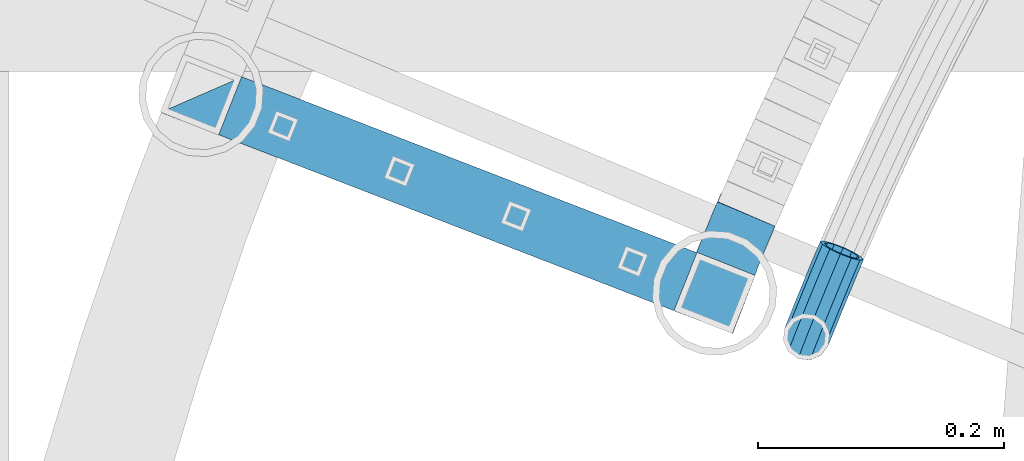
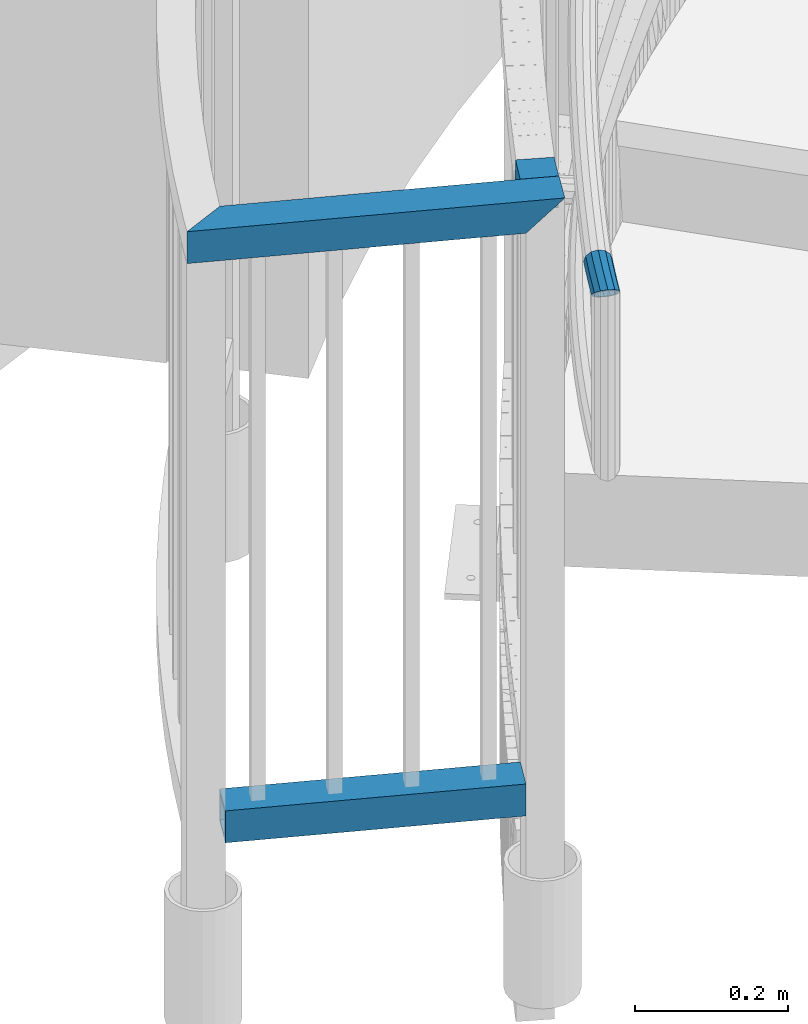
# One storey, part 480 of 975: 4 beams.
"""IFC2X3 building model written with IfcOpenShell, lengths in millimetres."""

from ifc_helpers import new_model, si_unit, frame, origin_with_axes, place, context, subcontext, project, spatial, faceted_brep, material, type_object, element, save


model = new_model("IFC2X3")

# Units and contexts
model_context = context("Model", 3, precision=1e-05, world=origin_with_axes())
body_context = subcontext(model_context, "Body", "Model", "MODEL_VIEW")
ifc_project = project(units=[si_unit("LENGTHUNIT", "METRE", prefix="MILLI"), si_unit("AREAUNIT", "SQUARE_METRE"), si_unit("VOLUMEUNIT", "CUBIC_METRE"), si_unit("MASSUNIT", "GRAM", prefix="KILO"), si_unit("TIMEUNIT", "SECOND"), si_unit("PLANEANGLEUNIT", "RADIAN"), si_unit("SOLIDANGLEUNIT", "STERADIAN"), si_unit("THERMODYNAMICTEMPERATUREUNIT", "DEGREE_CELSIUS"), si_unit("LUMINOUSINTENSITYUNIT", "LUMEN")], contexts=[model_context])

# Site, building, storey
site_placement = place(None, origin_with_axes())
site = spatial("IfcSite", under=ifc_project, at=site_placement, CompositionType="ELEMENT")
building_placement = place(site_placement, origin_with_axes())
building = spatial("IfcBuilding", under=site, at=building_placement, Name="Undefined", CompositionType="ELEMENT")
storey_placement = place(building_placement, origin_with_axes())
storey = spatial("IfcBuildingStorey", under=building, at=storey_placement, Name="Undefined", CompositionType="ELEMENT", Elevation=0.0)

# Beams
ifc_material = material()
beam_type_1 = type_object("IfcBeamType", PredefinedType="NOTDEFINED")
beam_1_placement = place(storey_placement, frame((32141.6837100169, 4427.4633907106, 895.35), z_axis=(-0.921304073140395, 0.388842905059251, 0.0), x_axis=(0.388842905059251, 0.921304073140395, 0.0)))
element("IfcBeam", 1, at=beam_1_placement, inside=storey, type_object=beam_type_1, material=ifc_material, Name="HANDRAIL", context=body_context, shape_type="Brep", body=[
    faceted_brep([(25.8282079449309, 16.4977839420935, 10.0075676482193), (25.7308276101321, 9.52499999999998, 16.9796715612138), (38.7896490832063, 9.52499999999998, 17.1316638384778), (38.8545704789321, 16.4977839420935, 10.1591821342627), (51.8490366294463, 9.52499999999998, 17.2228605224882), (51.8814976790673, 16.4977839420935, 10.2501521402701), (64.9087072153307, 9.52499999999998, 17.25325963676), (64.9087072153307, 16.4977839420935, 10.2804756946607), (51.8371550606498, 0.0, 19.7750489235623), (64.9087072153307, 0.0, 19.8054756946658), (38.765886203124, 0.0, 19.683769269639), (25.6951839337671, 0.0, 19.5316387111925), (12.6728552314671, 9.52499999999998, 16.7668869847985), (12.6253315313188, 0.0, 19.3186605453229), (-0.443387743907806, 0.0, 19.0448393878469), (-0.383985049949843, -9.52499999999998, 16.4933147208685), (12.6728552314671, -9.52499999999998, 16.7668869847985), (25.7308276101321, -9.52499999999998, 16.9796715612138), (38.7896490832063, -9.52499999999998, 17.1316638384778), (51.8490366294463, -9.52499999999998, 17.2228605224882), (64.9087072153307, -9.52499999999998, 17.25325963676), (51.8814976790673, -16.4977839420935, 10.2501521402701), (64.9087072153307, -16.4977839420935, 10.2804756946607), (38.8545704789321, -16.4977839420935, 10.1591821342627), (25.8282079449309, -16.4977839420935, 10.0075676482193), (12.802692394831, -16.4977839420935, 9.79531196804601), (-0.221693871953903, -16.4977839420935, 9.5224196939198), (-12.9786465048091, -19.05, -0.332387692884367), (-12.7126244291394, -16.4977839420935, -9.8536721259552), (0.221693871957541, -16.4977839420935, -9.52241969393071), (-2.63386027654633e-07, -19.0500000000029, 0.0), (-13.2446685804789, -16.4977839420935, 9.18889674017919), (12.9800532583431, -19.05, 0.271963390772726), (25.9612319560911, -19.05, 0.48349658524603), (38.9432547547403, -19.05, 0.634594998889952), (51.9258402974883, -19.05, 0.725255356981506), (64.9087072153343, -19.05, 0.755475694651977), (51.9701829159058, -16.4977839420935, -8.79964142630706), (64.9087072153343, -16.4977839420935, -8.76952430534948), (39.0319390305485, -16.4977839420935, -8.8899921364864), (26.0942559672549, -16.4977839420935, -9.04057447773084), (13.1574141218553, -16.4977839420935, -9.25138518649692), (0.38398504995348, -9.52499999999998, -16.4933147208758), (0.443387743911444, 0.0, -19.0448393878578), (13.3347749853674, 0.0, -18.7747337637702), (13.2872512852191, -9.52499999999998, -16.2229602032457), (26.19163630205, -9.52499999999998, -16.0126783907217), (39.0968604262744, -9.52499999999998, -15.8624738407016), (52.0026439655303, -9.52499999999998, -15.7723498085252), (64.9087072153343, -9.52499999999998, -15.7423082474488), (52.0145255343268, 0.0, -18.3245382095993), (64.9087072153343, 0.0, -18.2945243053582), (39.1206233063604, 0.0, -18.4145792718591), (26.227279978415, 0.0, -18.5646455407004), (13.2872512852191, 9.52499999999998, -16.2229602032457), (26.19163630205, 9.52499999999998, -16.0126783907217), (39.0968604262744, 9.52499999999998, -15.8624738407016), (52.0026439655303, 9.52499999999998, -15.7723498085252), (64.9087072153343, 9.52499999999998, -15.7423082474488), (51.9701829159058, 16.4977839420935, -8.79964142630706), (64.9087072153343, 16.4977839420935, -8.76952430534948), (39.0319390305485, 16.4977839420935, -8.8899921364864), (26.0942559672549, 16.4977839420935, -9.04057447773084), (25.9612319560911, 19.05, 0.48349658524603), (38.9432547547403, 19.05, 0.634594998889952), (51.9258402974883, 19.05, 0.725255356981506), (64.9087072153343, 19.05, 0.755475694651977), (77.3648074792327, 19.05, 0.726481516496278), (76.9388767530545, 16.4977839420935, -8.79752704067141), (75.8195085449479, 9.52499999999998, -15.7677054191918), (74.3066366623061, 0.0, -18.3163999514218), (72.805633904336, -9.52499999999998, -15.76068999571), (71.7186927478688, -16.4977839420935, -8.78537597076865), (71.3370581980053, -19.05, 0.740512363459857), (71.7629889241798, -16.4977839420935, 10.2645209206312), (72.8823571322901, -9.52499999999998, 17.2346992991406), (74.3952290149318, 0.0, 19.7833938313779), (75.8962317729056, 9.52499999999998, 17.2276838756625), (76.9831729293692, 16.4977839420935, 10.2523698507248), (17.6466109170033, 19.05, 0.348006704844011), (14.8706654742964, 16.4977839420935, 9.8290103679974), (12.7643684389404, 14.4396315817753, 11.8531074906132), (7.73531374615777, 9.52499999999998, 16.6634335938325), (-0.434629931831296, 1.40428244019654, 18.6686649746625), (-1.84727105193087, 0.0, 19.0088854435235), (-11.3088929325968, -9.52499999999998, 16.2135239950221), (-13.3801476945264, -11.6469137351224, 14.0378746917268), (-18.1146737379131, -16.4977839420935, 9.04148458933923), (-20.4416500639127, -19.05, -0.558288358450227), (-17.6665438794953, -16.4977839420935, -10.0036243123795), (-12.5735908365059, -11.5196445659184, -14.8298696008133), (-10.5327251734561, -9.52499999999998, -16.7728955017956), (-0.951029722582462, 0.0, -19.0805509086531), (0.434687823712011, 1.39499969402129, -18.6711516052092), (8.51148240332623, 9.52499999999998, -16.3230240683843), (13.1978639579211, 14.3254631666617, -11.4233293299185), (15.3187968882012, 16.4977839420935, -9.21616464052568), (12.836982161778, 13.3082123799554, 7.95413124310653), (11.7249554015616, 13.3082123799554, 7.93083160308743), (12.9128894969181, 14.4005160360366, 3.87830528124687), (12.7322468499951, 7.68349999999998, 13.5778684232901), (5.96928771430976, 7.68349999999998, 13.4361681342634), (-12.7640553637684, -13.3082123799554, -8.0128904688936), (-12.9786465048091, -15.367, -0.332387692884367), (-2.1246523829177e-07, -15.367000000002, 0.0), (0.178833056714211, -13.3082123799554, -7.68141855310751), (-13.1932376458535, -13.3082123799554, 7.34811508312487), (-0.178833056710573, -13.3082123799554, 7.68141855309659), (12.836982161778, -13.3082123799554, 7.95413124310653), (12.9800532583431, -15.367, 0.271963390772726), (13.1231243549082, -13.3082123799554, -7.41020446155744), (0.309747940296802, -7.68349999999998, -13.3046072081779), (13.2278596666874, -7.68349999999998, -13.0339416417337), (0.357666113421146, 0.0, -15.3628371062041), (13.2661954514733, 0.0, -15.0923723138876), (13.1231243549082, 13.3082123799554, -7.41020446155744), (13.0497213343151, 14.3644790452753, -3.46884706227866), (12.0864398226367, 13.3082123799554, -7.43192550036838), (13.2278596666874, 7.68349999999998, -13.0339416417337), (6.59539709775709, 7.68349999999998, -13.1729077132622), (0.348960484243435, 1.3959151074331, -14.9889041057213), (-1.03766638442175, 0.0, -15.3985720612764), (-8.76690071479243, -7.68349999999998, -13.5370633664097), (-12.714724737034, -11.5419145324909, -9.77849930871162), (-14.5217597188421, -13.3082123799554, -8.06609513113654), (-16.760345374274, -15.367, -0.446857461636682), (-14.8832511379696, -13.3082123799554, 7.29695938291479), (-13.2402522840785, -11.6248391938348, 9.03083160932511), (-0.309747940293164, -7.68349999999998, 13.304607208167), (-9.39300937383086, -7.68349999999998, 13.0719816943529), (-0.357666113417508, 0.0, 15.3628371061932), (-1.76063439009522, 0.0, 15.3269065961467), (-0.348914009562577, 1.40336714869977, 14.9869078781921), (12.6939110652092, 0.0, 15.6362990954367), (12.7322468499951, -7.68349999999998, 13.5778684232901), (25.7753724503527, -7.68349999999998, 13.7904110658601), (25.8539259204226, -13.3082123799554, 8.16624724271242), (25.9612319560911, -15.367, 0.48349658524603), (26.0685379917632, -13.3082123799554, -7.19925407222036), (26.1470914618294, -7.68349999999998, -12.8234178953644), (26.1758440274316, 0.0, -14.8820047296831), (26.1470914618294, 7.68349999999998, -12.8234178953644), (26.0685379917632, 13.3082123799554, -7.19925407222036), (25.9612319560911, 15.367, 0.48349658524603), (13.9640962499288, 15.367, 0.287998741827323), (25.8539259204226, 13.3082123799554, 8.16624724271242), (25.7753724503527, 7.68349999999998, 13.7904110658601), (25.7466198847505, 0.0, 15.8489979001788), (38.8001774564364, 0.0, 16.0009289106274), (38.8193461797055, -7.68349999999998, 13.9422305294902), (38.8717161055902, -13.3082123799554, 8.31776195475686), (38.9432547547403, -15.367, 0.634594998889952), (39.0147934038941, -13.3082123799554, -7.0485719569806), (39.0671633297789, -7.68349999999998, -12.6730405317103), (39.086332053048, 0.0, -14.7317389128511), (39.0671633297789, 7.68349999999998, -12.6730405317103), (39.0147934038941, 13.3082123799554, -7.0485719569806), (38.9432547547403, 15.367, 0.634594998889952), (38.8717161055902, 13.3082123799554, 8.31776195475686), (38.8193461797055, 7.68349999999998, 13.9422305294902), (51.8638853386001, 7.68349999999998, 14.0333235238213), (51.8543008731067, 0.0, 16.0920888340188), (51.8638853386001, -7.68349999999998, 14.0333235238213), (51.8900705852975, -13.3082123799554, 8.40867209549833), (51.9258402974883, -15.367, 0.725255356981506), (51.9616100096791, -13.3082123799554, -6.95816138153896), (51.9877952563766, -7.68349999999998, -12.5828128098619), (51.9973797218699, 0.0, -14.6415781200594), (51.9877952563766, 7.68349999999998, -12.5828128098619), (51.9616100096791, 13.3082123799554, -6.95816138153896), (51.9258402974883, 15.367, 0.725255356981506), (51.8900705852975, 13.3082123799554, 8.40867209549833), (64.9087072153307, 13.3082123799554, 8.43897569466208), (64.9087072153307, 7.68349999999998, 14.0636880746206), (64.9087072153307, 0.0, 16.1224756946649), (64.9087072153307, -7.68349999999998, 14.0636880746206), (64.9087072153307, -13.3082123799554, 8.43897569466208), (64.9087072153343, -15.367, 0.755475694651977), (64.9087072153307, -13.3082123799554, -6.92802430535085), (64.9087072153343, -7.68349999999998, -12.5527366853094), (64.9087072153343, 0.0, -14.6115243053537), (64.9087072153343, 7.68349999999998, -12.5527366853094), (64.9087072153307, 13.3082123799554, -6.92802430535085), (64.9087072153343, 15.367, 0.755475694651977), (76.7821250487141, 15.367, 0.727837831702345), (76.47427317849, 13.3082123799554, 8.41205442131104), (75.5974739789417, 7.68349999999998, 14.0388077347634), (74.3866650875098, 0.0, 16.1004137657073), (73.1662817688448, -7.68349999999998, 14.0444668430391), (72.2633247476369, -13.3082123799554, 8.42185628437073), (71.9197406285239, -15.367, 0.739156048250152), (72.227592498748, -13.3082123799554, -6.94506054135854), (73.1043916982962, -7.68349999999998, -12.5718138548109), (74.3152005897282, 0.0, -14.6334198857512), (75.5355839083895, 7.68349999999998, -12.5774729630866), (76.4385409295974, 13.3082123799554, -6.9548624044146)], [[[0, 1, 2, 3]], [[3, 2, 4, 5]], [[5, 4, 6, 7]], [[4, 8, 9, 6]], [[2, 10, 8, 4]], [[1, 11, 10, 2]], [[12, 13, 11, 1]], [[14, 15, 16, 13]], [[13, 16, 17, 11]], [[11, 17, 18, 10]], [[10, 18, 19, 8]], [[8, 19, 20, 9]], [[19, 21, 22, 20]], [[18, 23, 21, 19]], [[17, 24, 23, 18]], [[16, 25, 24, 17]], [[15, 26, 25, 16]], [[27, 28, 29, 30]], [[31, 27, 30, 26]], [[26, 30, 32, 25]], [[25, 32, 33, 24]], [[24, 33, 34, 23]], [[23, 34, 35, 21]], [[21, 35, 36, 22]], [[35, 37, 38, 36]], [[34, 39, 37, 35]], [[33, 40, 39, 34]], [[32, 41, 40, 33]], [[30, 29, 41, 32]], [[42, 43, 44, 45]], [[29, 42, 45, 41]], [[41, 45, 46, 40]], [[40, 46, 47, 39]], [[39, 47, 48, 37]], [[37, 48, 49, 38]], [[48, 50, 51, 49]], [[47, 52, 50, 48]], [[46, 53, 52, 47]], [[45, 44, 53, 46]], [[44, 54, 55, 53]], [[53, 55, 56, 52]], [[52, 56, 57, 50]], [[50, 57, 58, 51]], [[57, 59, 60, 58]], [[56, 61, 59, 57]], [[55, 62, 61, 56]], [[62, 63, 64, 61]], [[61, 64, 65, 59]], [[59, 65, 66, 60]], [[60, 66, 67, 68]], [[58, 60, 68, 69]], [[51, 58, 69, 70]], [[49, 51, 70, 71]], [[38, 49, 71, 72]], [[36, 38, 72, 73]], [[22, 36, 73, 74]], [[20, 22, 74, 75]], [[9, 20, 75, 76]], [[6, 9, 76, 77]], [[7, 6, 77, 78]], [[66, 7, 78, 67]], [[65, 5, 7, 66]], [[64, 3, 5, 65]], [[63, 0, 3, 64]], [[0, 63, 79, 80]], [[12, 1, 0, 80, 81]], [[12, 81, 82]], [[14, 13, 12, 82, 83]], [[14, 83, 84]], [[15, 14, 84, 85]], [[31, 26, 15, 85, 86]], [[31, 86, 87]], [[27, 31, 87, 88]], [[28, 27, 88, 89]], [[28, 89, 90]], [[42, 29, 28, 90, 91]], [[43, 42, 91, 92]], [[43, 92, 93]], [[54, 44, 43, 93, 94]], [[54, 94, 95]], [[62, 55, 54, 95, 96]], [[63, 62, 96, 79]], [[97, 98, 99]], [[97, 100, 101, 98]], [[102, 103, 104, 105]], [[103, 106, 107, 104]], [[104, 107, 108, 109]], [[105, 104, 109, 110]], [[111, 105, 110, 112]], [[113, 111, 112, 114]], [[115, 116, 117]], [[118, 115, 117, 119]], [[113, 114, 118, 119, 120]], [[113, 120, 121]], [[111, 113, 121, 122]], [[102, 105, 111, 122, 123]], [[102, 123, 124]], [[103, 102, 124, 125]], [[106, 103, 125, 126]], [[106, 126, 127]], [[128, 107, 106, 127, 129]], [[130, 128, 129, 131]], [[130, 131, 132]], [[100, 133, 130, 132, 101]], [[128, 130, 133, 134]], [[107, 128, 134, 108]], [[108, 134, 135, 136]], [[109, 108, 136, 137]], [[110, 109, 137, 138]], [[112, 110, 138, 139]], [[114, 112, 139, 140]], [[118, 114, 140, 141]], [[115, 118, 141, 142]], [[115, 142, 143, 144, 116]], [[95, 94, 93, 92, 91, 90, 89, 88, 87, 86, 85, 84, 83, 82, 81, 80, 79, 96], [98, 101, 132, 131, 129, 127, 126, 125, 124, 123, 122, 121, 120, 119, 117, 116, 144, 99]], [[143, 145, 97, 99, 144]], [[100, 97, 145, 146]], [[133, 100, 146, 147]], [[134, 133, 147, 135]], [[135, 147, 148, 149]], [[136, 135, 149, 150]], [[137, 136, 150, 151]], [[138, 137, 151, 152]], [[139, 138, 152, 153]], [[140, 139, 153, 154]], [[141, 140, 154, 155]], [[142, 141, 155, 156]], [[143, 142, 156, 157]], [[145, 143, 157, 158]], [[146, 145, 158, 159]], [[147, 146, 159, 148]], [[148, 159, 160, 161]], [[149, 148, 161, 162]], [[150, 149, 162, 163]], [[151, 150, 163, 164]], [[152, 151, 164, 165]], [[153, 152, 165, 166]], [[154, 153, 166, 167]], [[155, 154, 167, 168]], [[156, 155, 168, 169]], [[157, 156, 169, 170]], [[158, 157, 170, 171]], [[159, 158, 171, 160]], [[160, 171, 172, 173]], [[161, 160, 173, 174]], [[162, 161, 174, 175]], [[163, 162, 175, 176]], [[164, 163, 176, 177]], [[165, 164, 177, 178]], [[166, 165, 178, 179]], [[167, 166, 179, 180]], [[168, 167, 180, 181]], [[169, 168, 181, 182]], [[170, 169, 182, 183]], [[171, 170, 183, 172]], [[172, 183, 184, 185]], [[173, 172, 185, 186]], [[174, 173, 186, 187]], [[175, 174, 187, 188]], [[176, 175, 188, 189]], [[177, 176, 189, 190]], [[178, 177, 190, 191]], [[179, 178, 191, 192]], [[180, 179, 192, 193]], [[181, 180, 193, 194]], [[182, 181, 194, 195]], [[183, 182, 195, 184]], [[77, 76, 75, 74, 73, 72, 71, 70, 69, 68, 67, 78], [194, 193, 192, 191, 190, 189, 188, 187, 186, 185, 184, 195]]]),
])
beam_type_2 = type_object("IfcBeamType", Name="HSS2X2X.188_TUBES", PredefinedType="NOTDEFINED")
beam_2_placement = place(storey_placement, frame((32066.5014629083, 4461.8210761867, 1041.4), z_axis=(-0.919717574537065, 0.392580670802394, 0.0), x_axis=(0.392580670802394, 0.919717574537065, 0.0)))
element("IfcBeam", 2, at=beam_2_placement, inside=storey, type_object=beam_type_2, material=ifc_material, Name="HANDRAIL", ObjectType="HSS2X2X.188_TUBES", context=body_context, shape_type="Brep", body=[
    faceted_brep([(44.9440997901511, -25.4000000000001, -23.9583783324597), (44.9440997901511, 25.4, -23.9583783324597), (59.5414950854538, 25.4, -23.7562614783128), (59.5414950854538, -25.4000000000001, -23.7562614783128), (30.349191845904, -25.4000000000001, -24.2952206234258), (30.349191845904, 25.4, -24.2952206234258), (26.0398558151137, -25.4000000000001, -24.4344842420396), (26.0398558151137, 25.4, -24.4344842420396), (28.9426987109109, -25.4000000000001, 26.4853049454832), (28.9426987109109, 25.4, 26.4853049454832), (24.7276275894656, 25.4, 26.3490876598225), (24.7276275894656, -25.4000000000001, 26.3490876598225), (44.0063711249022, -25.4000000000001, 26.8329660575437), (44.0063711249022, 25.4, 26.8329660575437), (59.0726107795781, -25.4000000000001, 27.0415745730497), (59.0726107795781, 25.4, 27.0415745730497), (74.1401341092751, 25.4, 27.1111127196418), (69.0846625519407, -25.4000000000001, 27.0877812062536), (74.1401341092751, 7.15940677348681, 27.1111127196418), (76.9723809584866, 25.4, 27.0980416135062), (74.1401341092642, 25.4, -23.6888872802883), (77.0605330469334, 25.4, -23.7023652172429), (74.1401341092642, 6.59167857985699, -23.6888872802883), (69.1728132284807, -25.4000000000001, -23.7118119693732), (44.8561877277862, 20.6375, -19.1966897958955), (44.8561877277862, -20.6375, -19.1966897958955), (59.4975371817782, -20.6375, -18.993964348494), (59.4975371817782, 20.6375, -18.993964348494), (30.2173331144986, 20.6375, -19.5345463513368), (30.2173331144986, -20.6375, -19.5345463513368), (25.9168344189602, 20.6375, -19.6735243762414), (25.9168344189602, -20.6375, -19.6735243762414), (24.8506489856227, 20.6375, 21.5881277940243), (24.8506489856227, -20.6375, 21.5881277940243), (29.0745574423199, 20.6375, 21.7246306733978), (29.0745574423199, -20.6375, 21.7246306733978), (44.0942831872708, 20.6375, 22.0712775209795), (44.0942831872708, -20.6375, 22.0712775209795), (59.1165686832537, 20.6375, 22.2792774432346), (59.1165686832537, -20.6375, 22.2792774432346), (74.1401341092751, 20.6375, 22.3486127196484), (76.2411640249193, 20.6375, 22.3389162537424), (74.1401341092751, 7.10618225533403, 22.3486127196484), (69.8323960256748, -20.6375, 22.3287320719937), (69.9040184503647, -20.6375, -18.9459373832033), (74.1401341092642, 20.6375, -18.9263872802949), (74.1401341092642, 6.64490309800976, -18.9263872802949), (76.3127875967839, 20.6375, -18.9364142962477)], [[[0, 1, 2, 3]], [[4, 5, 1, 0]], [[5, 4, 6, 7]], [[8, 9, 10, 11]], [[9, 8, 12, 13]], [[13, 12, 14, 15]], [[16, 15, 14, 17, 18]], [[16, 18, 19]], [[20, 2, 1, 5, 7, 10, 9, 13, 15, 16, 19, 21]], [[20, 21, 22]], [[3, 2, 20, 22, 23]], [[14, 12, 8, 11, 6, 4, 0, 3, 23, 17]], [[24, 25, 26, 27]], [[28, 29, 25, 24]], [[29, 28, 30, 31]], [[10, 7, 6, 11], [32, 33, 31, 30]], [[34, 35, 33, 32]], [[35, 34, 36, 37]], [[37, 36, 38, 39]], [[40, 41, 42]], [[39, 38, 40, 42, 43]], [[26, 25, 29, 31, 33, 35, 37, 39, 43, 44]], [[45, 27, 26, 44, 46]], [[45, 46, 47]], [[40, 38, 36, 34, 32, 30, 28, 24, 27, 45, 47, 41]], [[17, 23, 22, 21, 19, 18], [46, 44, 43, 42, 41, 47]]]),
])
beam_3_placement = place(storey_placement, frame((31648.9149123785, 4623.21435817746, 1041.4), z_axis=(0.36050233200315, 0.932758312008149, 0.0), x_axis=(0.932758312008149, -0.36050233200315, 0.0)))
element("IfcBeam", 3, at=beam_3_placement, inside=storey, type_object=beam_type_2, material=ifc_material, Name="HANDRAIL", ObjectType="HSS2X2X.188_TUBES", context=body_context, shape_type="Brep", body=[
    faceted_brep([(-20.5550632567101, 20.6375, -20.6374999999789), (-20.5550632567101, -20.6375, -20.6374999999789), (468.508199112846, -20.6375, -20.6375000003191), (426.871761889415, 20.6375, -20.6375000002918), (21.1960912286122, -20.6375, 20.6374999999771), (468.508199112748, -20.6375, 20.637499999666), (21.1960912286122, 20.6375, 20.6374999999771), (426.871761889317, 20.6375, 20.6374999996951), (-25.3725041588623, 25.4, -25.399999999976), (26.0135321307644, 25.4, 25.3999999999724), (422.067557594295, 25.4, 25.3999999996995), (422.067557594411, 25.4, -25.400000000287), (26.0135321307644, -25.4000000000001, 25.3999999999724), (473.312403407745, -25.4000000000001, 25.3999999996613), (-25.3725041588623, -25.4000000000001, -25.399999999976), (473.312403407865, -25.4000000000001, -25.4000000003216)], [[[0, 1, 2, 3]], [[1, 4, 5, 2]], [[4, 6, 7, 5]], [[6, 0, 3, 7]], [[8, 9, 10, 11]], [[9, 12, 13, 10]], [[12, 14, 15, 13]], [[14, 8, 11, 15]], [[13, 15, 11, 10], [5, 7, 3, 2]], [[14, 12, 9, 8], [6, 4, 1, 0]]]),
])
beam_4_placement = place(storey_placement, frame((31648.9149123785, 4623.21435817746, 114.3), z_axis=(0.36050233200315, 0.932758312008149, 0.0), x_axis=(0.932758312008149, -0.36050233200315, 0.0)))
element("IfcBeam", 4, at=beam_4_placement, inside=storey, type_object=beam_type_2, material=ifc_material, Name="HANDRAIL", ObjectType="HSS2X2X.188_TUBES", context=body_context, shape_type="Brep", body=[
    faceted_brep([(25.2437060822522, 20.6375, -20.6375000000116), (25.2437060822522, -20.6375, -20.6375000000116), (422.107474053882, -20.6375, -20.6375000002881), (422.107474053882, 20.6375, -20.6375000002881), (25.5577644509794, -20.6375, 20.6374999999753), (422.470521904965, -20.6375, 20.6374999996988), (25.5577644509794, 20.6375, 20.6374999999753), (422.470521904965, 20.6375, 20.6374999996988), (25.2074685781663, 25.4, -25.4000000000087), (25.5940019550653, 25.4, 25.3999999999724), (422.512412041626, 25.4, 25.3999999996959), (422.065583917214, 25.4, -25.4000000002852), (25.5940019550653, -25.4, 25.3999999999724), (422.512412041626, -25.4, 25.3999999996959), (25.2074685781663, -25.4, -25.4000000000087), (422.065583917214, -25.4, -25.4000000002852)], [[[0, 1, 2, 3]], [[1, 4, 5, 2]], [[4, 6, 7, 5]], [[6, 0, 3, 7]], [[8, 9, 10, 11]], [[9, 12, 13, 10]], [[12, 14, 15, 13]], [[14, 8, 11, 15]], [[13, 15, 11, 10], [5, 7, 3, 2]], [[14, 12, 9, 8], [6, 4, 1, 0]]]),
])

save(model, "model.ifc")
